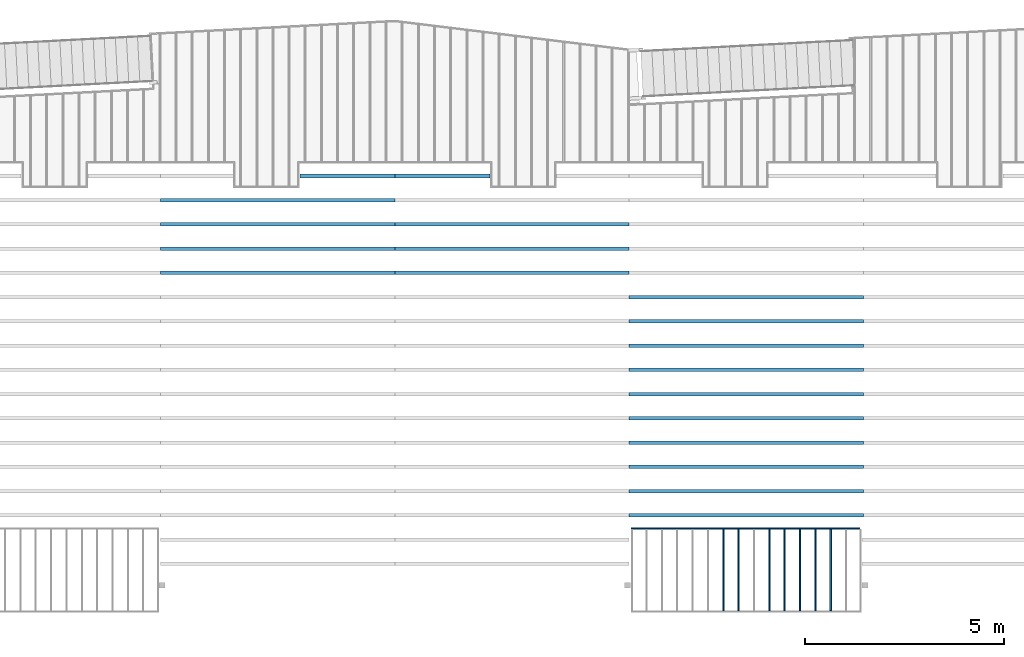
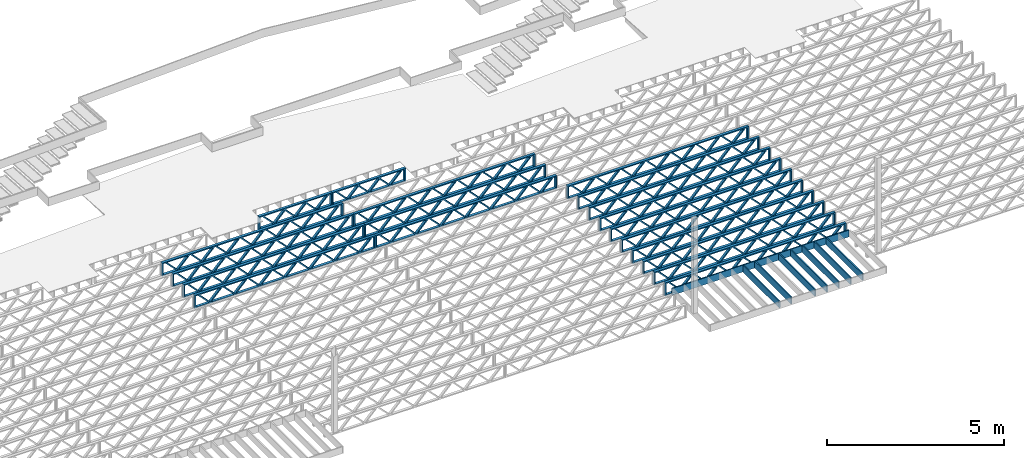
# One storey, part 7 of 23: 27 beams, 4 elements without a shape of their own.
"""IFC4 building model written with IfcOpenShell, lengths in feet."""

import ifcopenshell
import ifcopenshell.guid

model = None  # the IFC model being written
_history = None  # IfcOwnerHistory: only IFC2X3 demands one
_inside = {}  # id of a spatial element -> (the spatial element, [elements in it])
_under = {}  # id of a project, library or spatial element -> (it, [spatial elements below it])
_declared = {}  # id of a project -> (the project, [libraries it declares])
_typed = {}  # id of a type object -> (the type object, [elements of that type])
_made_of = {}  # id of a material, layer set ... -> (it, [elements and type objects made of it])


def new_model(schema):
    """Start an empty IFC model of exactly this schema.

    Asked for "IFC4X3", IfcOpenShell would pick the latest addendum, in which some entities
    have other attributes; the version numbers below select the first issue.
    IFC2X3 requires an IfcOwnerHistory on every rooted entity: one is made here for all.
    """
    global model, _history
    if schema == "IFC4X3":
        model = ifcopenshell.file(schema_version=(4, 3, 0, 0))
    else:
        model = ifcopenshell.file(schema=schema)
    _inside.clear()
    _under.clear()
    _declared.clear()
    _typed.clear()
    _made_of.clear()
    _history = None
    if model.schema == "IFC2X3":
        org = make("IfcOrganization", Name="unknown")
        user = make(
            "IfcPersonAndOrganization",
            ThePerson=make("IfcPerson", FamilyName="unknown"),
            TheOrganization=org,
        )
        app = make(
            "IfcApplication",
            ApplicationDeveloper=org,
            Version="unknown",
            ApplicationFullName="unknown",
            ApplicationIdentifier="unknown",
        )
        _history = make(
            "IfcOwnerHistory",
            OwningUser=user,
            OwningApplication=app,
            ChangeAction="ADDED",
            CreationDate=0,
        )
    return model


def make(cls, **values):
    """One entity of the class cls with the attributes given. An attribute that is None is left unset."""
    return model.create_entity(
        cls, **{name: value for name, value in values.items() if value is not None}
    )


def entity(cls, *values):
    """Any entity or typed value of the class cls, its attributes in the order of the schema. None: left unset."""
    e = model.create_entity(cls)
    for i, value in enumerate(values):
        if value is not None:
            e[i] = value
    return e


def rooted(cls, **values):
    """An entity with a GlobalId (a new one), such as an element, a storey or a relation."""
    return make(cls, GlobalId=ifcopenshell.guid.new(), OwnerHistory=_history, **values)


def si_unit(unit_type, name, prefix=None):
    """IfcSIUnit, for example si_unit("LENGTHUNIT", "METRE", prefix="MILLI")."""
    return make("IfcSIUnit", UnitType=unit_type, Prefix=prefix, Name=name)


def converted_unit(unit_type, name, factor, base, dimensions=None, offset=None):
    """IfcConversionBasedUnit, such as the inch: factor (a typed value) times the base unit."""
    return make(
        "IfcConversionBasedUnit"
        if offset is None
        else "IfcConversionBasedUnitWithOffset",
        ConversionOffset=offset,
        Dimensions=None
        if dimensions is None
        else entity("IfcDimensionalExponents", *dimensions),
        UnitType=unit_type,
        Name=name,
        ConversionFactor=make(
            "IfcMeasureWithUnit", ValueComponent=factor, UnitComponent=base
        ),
    )


def derived_unit(unit_type, elements):
    """IfcDerivedUnit: a product of units, each with its exponent."""
    return make(
        "IfcDerivedUnit",
        Elements=[
            make("IfcDerivedUnitElement", Unit=unit, Exponent=power)
            for unit, power in elements
        ],
        UnitType=unit_type,
    )


def assignment(units):
    """IfcUnitAssignment: the units of a project."""
    return None if units is None else make("IfcUnitAssignment", Units=units)


def point(xyz):
    """IfcCartesianPoint."""
    return None if xyz is None else make("IfcCartesianPoint", Coordinates=xyz)


def direction(xyz):
    """IfcDirection."""
    return None if xyz is None else make("IfcDirection", DirectionRatios=xyz)


def frame(location, z_axis=None, x_axis=None):
    """IfcAxis2Placement3D, a coordinate frame: its origin and axes. An axis left out is left unset."""
    return make(
        "IfcAxis2Placement3D",
        Location=point(location),
        Axis=direction(z_axis),
        RefDirection=direction(x_axis),
    )


def frame_2d(location, x_axis=None):
    """IfcAxis2Placement2D, a coordinate frame in the plane: its origin and x axis."""
    return make(
        "IfcAxis2Placement2D", Location=point(location), RefDirection=direction(x_axis)
    )


def origin():
    """The frame at (0, 0, 0) with its axes left unset."""
    return frame((0.0, 0.0, 0.0))


def origin_2d_with_axis():
    """The frame at (0, 0) in the plane with the x axis (1, 0) written out."""
    return frame_2d((0.0, 0.0), x_axis=(1.0, 0.0))


def place(relative_to, where):
    """IfcLocalPlacement: puts the frame where relative to a parent placement (None: the world)."""
    return make(
        "IfcLocalPlacement", PlacementRelTo=relative_to, RelativePlacement=where
    )


def context(
    kind, dimensions, precision=None, world=None, true_north=None, identifier=None
):
    """IfcGeometricRepresentationContext, for example the 3D "Model" context."""
    return make(
        "IfcGeometricRepresentationContext",
        ContextIdentifier=identifier,
        ContextType=kind,
        CoordinateSpaceDimension=dimensions,
        Precision=precision,
        WorldCoordinateSystem=world,
        TrueNorth=true_north,
    )


def subcontext(parent, identifier, kind, view, scale=None):
    """IfcGeometricRepresentationSubContext, for example "Body" below "Model"."""
    return make(
        "IfcGeometricRepresentationSubContext",
        ContextIdentifier=identifier,
        ContextType=kind,
        ParentContext=parent,
        TargetScale=scale,
        TargetView=view,
    )


def project(units=None, contexts=None):
    """IfcProject with its units and contexts."""
    return rooted(
        "IfcProject",
        Name="project",
        RepresentationContexts=contexts,
        UnitsInContext=assignment(units),
    )


def spatial(cls, under=None, at=None, **own):
    """A site, building, storey or space (cls), placed at a placement, below another one or the project."""
    s = rooted(cls, ObjectPlacement=at, **own)
    if under is not None:
        _under.setdefault(under.id(), (under, []))[1].append(s)
    return s


def profile(cls, at=None, kind="AREA", **sizes):
    """A parametric profile (cls). Its sizes go by their IFC names, for example OverallWidth=200.0."""
    return make(cls, ProfileType=kind, Position=at, **sizes)


def rectangle(**sizes):
    """IfcRectangleProfileDef."""
    return profile("IfcRectangleProfileDef", **sizes)


def extrude(swept, where, along, depth):
    """IfcExtrudedAreaSolid: the profile swept, set in the frame where, extruded along a direction by depth."""
    return make(
        "IfcExtrudedAreaSolid",
        SweptArea=swept,
        Position=where,
        ExtrudedDirection=direction(along),
        Depth=depth,
    )


def shape(context_of_items, identifier, shape_type, items):
    """IfcShapeRepresentation: the items that make up one representation, for example the "Body"."""
    return make(
        "IfcShapeRepresentation",
        ContextOfItems=context_of_items,
        RepresentationIdentifier=identifier,
        RepresentationType=shape_type,
        Items=items,
    )


def source(mapping_origin, context_of_items, identifier, shape_type, items):
    """IfcRepresentationMap: a shape defined once, which mapped items show again and again."""
    return make(
        "IfcRepresentationMap",
        MappingOrigin=mapping_origin,
        MappedRepresentation=shape(context_of_items, identifier, shape_type, items),
    )


def transform(
    local_origin,
    x_axis=None,
    y_axis=None,
    z_axis=None,
    scale=None,
    scale2=None,
    scale3=None,
    uniform=True,
):
    """IfcCartesianTransformationOperator3D, or its non-uniform kind. x_axis, y_axis, z_axis: its Axis1, 2, 3."""
    if uniform:
        return make(
            "IfcCartesianTransformationOperator3D",
            Axis1=direction(x_axis),
            Axis2=direction(y_axis),
            LocalOrigin=point(local_origin),
            Scale=scale,
            Axis3=direction(z_axis),
        )
    return make(
        "IfcCartesianTransformationOperator3DnonUniform",
        Axis1=direction(x_axis),
        Axis2=direction(y_axis),
        LocalOrigin=point(local_origin),
        Scale=scale,
        Axis3=direction(z_axis),
        Scale2=scale2,
        Scale3=scale3,
    )


def mapped(mapping_source, mapping_target):
    """IfcMappedItem: shows the shape of a source again, moved by a transform."""
    return make(
        "IfcMappedItem", MappingSource=mapping_source, MappingTarget=mapping_target
    )


def material(Name=None, Category=None):
    """IfcMaterial."""
    return make("IfcMaterial", Name=Name, Category=Category)


def material_profile(
    of_material, cross_section, Name=None, Category=None, Priority=None
):
    """IfcMaterialProfile: a cross section and its material."""
    return make(
        "IfcMaterialProfile",
        Name=Name,
        Material=of_material,
        Profile=cross_section,
        Priority=Priority,
        Category=Category,
    )


def profile_set(profiles, Name=None, composite=None):
    """IfcMaterialProfileSet."""
    return make(
        "IfcMaterialProfileSet",
        Name=Name,
        MaterialProfiles=profiles,
        CompositeProfile=composite,
    )


def profile_usage(for_profile_set, cardinal=None, extent=None):
    """IfcMaterialProfileSetUsage: how a profile set lies along its element."""
    return make(
        "IfcMaterialProfileSetUsage",
        ForProfileSet=for_profile_set,
        CardinalPoint=cardinal,
        ReferenceExtent=extent,
    )


def made_of(thing, what):
    """Note that an element or type object is made of a material, layer set ...; save() writes the relation."""
    if what is not None:
        _made_of.setdefault(what.id(), (what, []))[1].append(thing)
    return thing


def type_object(cls, material=None, **own):
    """A type object (cls), such as IfcWallType, which elements share."""
    return made_of(rooted(cls, **own), material)


def type_shapes(of_type, sources):
    """Give a type object the sources (RepresentationMaps) that its elements show as mapped items."""
    of_type.RepresentationMaps = sources


def element(
    cls,
    number,
    at=None,
    inside=None,
    cuts=None,
    type_object=None,
    material=None,
    context=None,
    identifier="Body",
    shape_type=None,
    held_by="IfcProductDefinitionShape",
    body=None,
    shapes=None,
    **own,
):
    """One element of the class cls, such as IfcWall. Its Tag is "e" and its number.

    at: its placement. inside: the storey or other place that contains it. cuts: it is an
    opening in that element (IfcRelVoidsElement). A single representation is given by context,
    identifier, shape_type and body (its items); several are given by shapes. held_by: the class
    of the entity that holds the representations. save() writes the other relations.
    """
    e = rooted(cls, Tag="e%d" % number, ObjectPlacement=at, **own)
    if body is not None:
        shapes = [shape(context, identifier, shape_type, body)]
    if shapes is not None:
        e.Representation = make(held_by, Representations=shapes)
    if inside is not None:
        _inside.setdefault(inside.id(), (inside, []))[1].append(e)
    if cuts is not None:
        rooted(
            "IfcRelVoidsElement", RelatingBuildingElement=cuts, RelatedOpeningElement=e
        )
    if type_object is not None:
        _typed.setdefault(type_object.id(), (type_object, []))[1].append(e)
    return made_of(e, material)


def aggregate(whole, parts):
    """IfcRelAggregates: a whole, such as a stair, and the parts it consists of."""
    return rooted("IfcRelAggregates", RelatingObject=whole, RelatedObjects=parts)


def save(model, path):
    """Write the relations noted so far, then the file.

    IfcRelAggregates (storeys below a building ...), IfcRelContainedInSpatialStructure (elements
    in a storey), IfcRelDefinesByType, IfcRelAssociatesMaterial and IfcRelDeclares: one each for
    every whole, place, type object, material and project.
    """
    for whole, parts in _under.values():
        aggregate(whole, parts)
    for where, things in _inside.values():
        rooted(
            "IfcRelContainedInSpatialStructure",
            RelatedElements=things,
            RelatingStructure=where,
        )
    for kind, things in _typed.values():
        rooted("IfcRelDefinesByType", RelatedObjects=things, RelatingType=kind)
    for what, things in _made_of.values():
        rooted("IfcRelAssociatesMaterial", RelatedObjects=things, RelatingMaterial=what)
    for by, libraries in _declared.values():
        rooted("IfcRelDeclares", RelatingContext=by, RelatedDefinitions=libraries)
    model.write(path)


model = new_model("IFC4")

# Units and contexts
model_context = context("Model", 3, precision=0.0001, world=origin(), true_north=direction((6.12303176911189e-17, 1.0)))
body_context = subcontext(model_context, "Body", "Model", "MODEL_VIEW")
ifc_project = project(units=[converted_unit("LENGTHUNIT", "FOOT", entity("IfcRatioMeasure", 0.3048), si_unit("LENGTHUNIT", "METRE"), dimensions=[1, 0, 0, 0, 0, 0, 0]), converted_unit("AREAUNIT", "SQUARE FOOT", entity("IfcRatioMeasure", 0.09290304), si_unit("AREAUNIT", "SQUARE_METRE"), dimensions=[2, 0, 0, 0, 0, 0, 0]), converted_unit("VOLUMEUNIT", "CUBIC FOOT", entity("IfcRatioMeasure", 0.028316846592), si_unit("VOLUMEUNIT", "CUBIC_METRE"), dimensions=[3, 0, 0, 0, 0, 0, 0]), converted_unit("PLANEANGLEUNIT", "DEGREE", entity("IfcRatioMeasure", 0.0174532925199433), si_unit("PLANEANGLEUNIT", "RADIAN"), dimensions=[0, 0, 0, 0, 0, 0, 0]), si_unit("MASSUNIT", "GRAM", prefix="KILO"), derived_unit("MASSDENSITYUNIT", [(si_unit("MASSUNIT", "GRAM", prefix="KILO"), 1), (si_unit("LENGTHUNIT", "METRE"), -3)]), derived_unit("MOMENTOFINERTIAUNIT", [(si_unit("LENGTHUNIT", "METRE"), 4)]), si_unit("TIMEUNIT", "SECOND"), si_unit("FREQUENCYUNIT", "HERTZ"), si_unit("THERMODYNAMICTEMPERATUREUNIT", "DEGREE_CELSIUS"), derived_unit("THERMALTRANSMITTANCEUNIT", [(si_unit("MASSUNIT", "GRAM", prefix="KILO"), 1), (si_unit("THERMODYNAMICTEMPERATUREUNIT", "KELVIN"), -1), (si_unit("TIMEUNIT", "SECOND"), -3)]), derived_unit("VOLUMETRICFLOWRATEUNIT", [(si_unit("LENGTHUNIT", "METRE"), 3), (si_unit("TIMEUNIT", "SECOND"), -1)]), si_unit("ELECTRICCURRENTUNIT", "AMPERE"), si_unit("ELECTRICVOLTAGEUNIT", "VOLT"), si_unit("POWERUNIT", "WATT"), si_unit("FORCEUNIT", "NEWTON"), si_unit("ILLUMINANCEUNIT", "LUX"), si_unit("LUMINOUSFLUXUNIT", "LUMEN"), si_unit("LUMINOUSINTENSITYUNIT", "CANDELA"), derived_unit("USERDEFINED", [(si_unit("MASSUNIT", "GRAM", prefix="KILO"), -1), (si_unit("LENGTHUNIT", "METRE"), -2), (si_unit("TIMEUNIT", "SECOND"), 3), (si_unit("LUMINOUSFLUXUNIT", "LUMEN"), 1)]), derived_unit("LINEARVELOCITYUNIT", [(si_unit("LENGTHUNIT", "METRE"), 1), (si_unit("TIMEUNIT", "SECOND"), -1)]), si_unit("PRESSUREUNIT", "PASCAL"), derived_unit("USERDEFINED", [(si_unit("LENGTHUNIT", "METRE"), -2), (si_unit("MASSUNIT", "GRAM", prefix="KILO"), 1), (si_unit("TIMEUNIT", "SECOND"), -2)]), derived_unit("LINEARFORCEUNIT", [(si_unit("MASSUNIT", "GRAM", prefix="KILO"), 1), (si_unit("LENGTHUNIT", "METRE"), 1), (si_unit("TIMEUNIT", "SECOND"), -2), (si_unit("LENGTHUNIT", "METRE"), -1)]), derived_unit("PLANARFORCEUNIT", [(si_unit("MASSUNIT", "GRAM", prefix="KILO"), 1), (si_unit("LENGTHUNIT", "METRE"), 1), (si_unit("TIMEUNIT", "SECOND"), -2), (si_unit("LENGTHUNIT", "METRE"), -2)])], contexts=[model_context])

# Site, building, storey
site_placement = place(None, origin())
site = spatial("IfcSite", under=ifc_project, at=site_placement, CompositionType="ELEMENT")
building_placement = place(site_placement, origin())
building = spatial("IfcBuilding", under=site, at=building_placement, CompositionType="ELEMENT")
storey_placement = place(building_placement, frame((0.0, 0.0, 10.8020833333333)))
storey = spatial("IfcBuildingStorey", under=building, at=storey_placement, Name="2ND FLOOR", CompositionType="ELEMENT", Elevation=10.8020833333333)

# Assembly, beams
assembly_1_placement = place(storey_placement, origin())
assembly_1 = element("IfcElementAssembly", 1, at=assembly_1_placement, inside=storey, Name="Structural Beam System:Structural Framing System", ObjectType="Structural Beam System:Structural Framing System", AssemblyPlace="NOTDEFINED", PredefinedType="BEAM_GRID")
ifc_material_1 = material(Category="Materials")
ifc_material_profile_1 = material_profile(ifc_material_1, rectangle(XDim=0.770833333333333, YDim=0.124999999999994, at=frame_2d((-5.55111512312578e-17, 0.0), x_axis=(1.0, 0.0))))
ifc_profile_set_1 = profile_set([ifc_material_profile_1])
ifc_profile_usage_1 = profile_usage(ifc_profile_set_1, cardinal=8)
beam_type_1 = type_object("IfcBeamType", PredefinedType="BEAM", material=ifc_profile_set_1)
shared_shape_1 = source(origin(), body_context, "Body", "SweptSolid", [
    extrude(rectangle(XDim=0.770833333333333, YDim=0.124999999999994, at=frame_2d((-5.55111512312578e-17, 0.0), x_axis=(1.0, 0.0))), frame((-3.35416666666737, 0.0, 0.0), z_axis=(1.0, 0.0, 0.0), x_axis=(0.0, 0.0, -1.0)), (0.0, 0.0, 1.0), 6.70833333333462),
])
type_shapes(beam_type_1, [shared_shape_1])
beam_1_placement = place(assembly_1_placement, frame((-167.102006703188, 925.341101549316, -0.645833333333471), z_axis=(0.0, 0.0, 1.0), x_axis=(0.0, 1.0, 0.0)))
beam_1 = element("IfcBeam", 2, at=beam_1_placement, type_object=beam_type_1, material=ifc_profile_usage_1, PredefinedType="BEAM", context=body_context, shape_type="MappedRepresentation", body=[
    mapped(shared_shape_1, transform((0.0, 0.0, 0.0), scale=1.0)),
])
ifc_profile_usage_2 = profile_usage(ifc_profile_set_1, cardinal=8)
beam_2_placement = place(assembly_1_placement, frame((-168.368890383746, 925.341101549316, -0.645833333333471), z_axis=(0.0, 0.0, 1.0), x_axis=(0.0, 1.0, 0.0)))
beam_2 = element("IfcBeam", 3, at=beam_2_placement, type_object=beam_type_1, material=ifc_profile_usage_2, PredefinedType="BEAM", context=body_context, shape_type="MappedRepresentation", body=[
    mapped(shared_shape_1, transform((0.0, 0.0, 0.0), scale=1.0)),
])
ifc_profile_usage_3 = profile_usage(ifc_profile_set_1, cardinal=8)
beam_3_placement = place(assembly_1_placement, frame((-169.635774064305, 925.341101549317, -0.645833333333471), z_axis=(0.0, 0.0, 1.0), x_axis=(0.0, 1.0, 0.0)))
beam_3 = element("IfcBeam", 4, at=beam_3_placement, type_object=beam_type_1, material=ifc_profile_usage_3, PredefinedType="BEAM", context=body_context, shape_type="MappedRepresentation", body=[
    mapped(shared_shape_1, transform((0.0, 0.0, 0.0), scale=1.0)),
])
ifc_profile_usage_4 = profile_usage(ifc_profile_set_1, cardinal=8)
beam_4_placement = place(assembly_1_placement, frame((-170.902657744863, 925.341101549317, -0.645833333333471), z_axis=(0.0, 0.0, 1.0), x_axis=(0.0, 1.0, 0.0)))
beam_4 = element("IfcBeam", 5, at=beam_4_placement, type_object=beam_type_1, material=ifc_profile_usage_4, PredefinedType="BEAM", context=body_context, shape_type="MappedRepresentation", body=[
    mapped(shared_shape_1, transform((0.0, 0.0, 0.0), scale=1.0)),
])
ifc_profile_usage_5 = profile_usage(ifc_profile_set_1, cardinal=8)
beam_5_placement = place(assembly_1_placement, frame((-172.169541425421, 925.341101549317, -0.645833333333471), z_axis=(0.0, 0.0, 1.0), x_axis=(0.0, 1.0, 0.0)))
beam_5 = element("IfcBeam", 6, at=beam_5_placement, type_object=beam_type_1, material=ifc_profile_usage_5, PredefinedType="BEAM", context=body_context, shape_type="MappedRepresentation", body=[
    mapped(shared_shape_1, transform((0.0, 0.0, 0.0), scale=1.0)),
])
ifc_profile_usage_6 = profile_usage(ifc_profile_set_1, cardinal=8)
beam_6_placement = place(assembly_1_placement, frame((-174.703308786538, 925.341101549318, -0.645833333333433), z_axis=(0.0, 0.0, 1.0), x_axis=(0.0, 1.0, 0.0)))
beam_6 = element("IfcBeam", 7, at=beam_6_placement, type_object=beam_type_1, material=ifc_profile_usage_6, PredefinedType="BEAM", context=body_context, shape_type="MappedRepresentation", body=[
    mapped(shared_shape_1, transform((0.0, 0.0, 0.0), scale=1.0)),
])
ifc_profile_usage_7 = profile_usage(ifc_profile_set_1, cardinal=8)
beam_7_placement = place(assembly_1_placement, frame((-175.970192467096, 925.341101549318, -0.645833333333471), z_axis=(0.0, 0.0, 1.0), x_axis=(0.0, 1.0, 0.0)))
beam_7 = element("IfcBeam", 8, at=beam_7_placement, type_object=beam_type_1, material=ifc_profile_usage_7, PredefinedType="BEAM", context=body_context, shape_type="MappedRepresentation", body=[
    mapped(shared_shape_1, transform((0.0, 0.0, 0.0), scale=1.0)),
])
aggregate(assembly_1, [beam_1, beam_2, beam_3, beam_4, beam_5, beam_6, beam_7])

assembly_2_placement = place(storey_placement, origin())
assembly_2 = element("IfcElementAssembly", 9, at=assembly_2_placement, inside=storey, Name="Structural Beam System:Structural Framing System", ObjectType="Structural Beam System:Structural Framing System", AssemblyPlace="NOTDEFINED", PredefinedType="BEAM_GRID")
ifc_material_2 = material(Name="WOOD TRUSS", Category="Materials")
ifc_material_profile_2 = material_profile(ifc_material_2, rectangle(XDim=1.73473973950632, YDim=0.125, at=frame_2d((-1.11022302462516e-16, 8.32667268468867e-17), x_axis=(1.0, 0.0))))
ifc_material_profile_3 = material_profile(ifc_material_2, rectangle(XDim=1.73473973950633, YDim=0.125, at=frame_2d((-1.11022302462516e-16, 8.32667268468867e-17), x_axis=(1.0, 0.0))))
ifc_material_profile_4 = material_profile(ifc_material_2, rectangle(XDim=1.73473973950632, YDim=0.125, at=frame_2d((-5.55111512312578e-17, 1.38777878078145e-16), x_axis=(1.0, 0.0))))
ifc_material_profile_5 = material_profile(ifc_material_2, rectangle(XDim=1.73473973950633, YDim=0.125, at=frame_2d((-1.11022302462516e-16, 8.32667268468867e-17), x_axis=(1.0, 0.0))))
ifc_material_profile_6 = material_profile(ifc_material_2, rectangle(XDim=1.73473973950632, YDim=0.125, at=frame_2d((-1.11022302462516e-16, 8.32667268468867e-17), x_axis=(1.0, 0.0))))
ifc_material_profile_7 = material_profile(ifc_material_2, rectangle(XDim=1.73473973950633, YDim=0.125, at=frame_2d((-2.77555756156289e-16, 3.05311331771918e-16), x_axis=(1.0, 0.0))))
ifc_material_profile_8 = material_profile(ifc_material_2, rectangle(XDim=1.73473973950632, YDim=0.124999999999999, at=frame_2d((-3.88578058618805e-16, -2.4980018054066e-16), x_axis=(1.0, 0.0))))
ifc_material_profile_9 = material_profile(ifc_material_2, rectangle(XDim=1.73473973950633, YDim=0.125, at=frame_2d((2.77555756156289e-16, -3.05311331771918e-16), x_axis=(1.0, 0.0))))
ifc_material_profile_10 = material_profile(ifc_material_2, rectangle(XDim=1.73473973950632, YDim=0.124999999999999, at=frame_2d((-1.11022302462516e-16, 8.32667268468867e-17), x_axis=(1.0, 0.0))))
ifc_material_profile_11 = material_profile(ifc_material_2, rectangle(XDim=1.73473973950633, YDim=0.125, at=origin_2d_with_axis()))
ifc_material_profile_12 = material_profile(ifc_material_2, rectangle(XDim=0.124999999999982, YDim=0.291666666666668, at=origin_2d_with_axis()))
ifc_material_profile_13 = material_profile(ifc_material_2, rectangle(XDim=0.124999999999932, YDim=0.291666666666664, at=origin_2d_with_axis()))
ifc_material_profile_14 = material_profile(ifc_material_2, rectangle(XDim=1.25000000000002, YDim=0.29166666666667, at=origin_2d_with_axis()))
ifc_material_profile_15 = material_profile(ifc_material_2, rectangle(XDim=1.25000000000004, YDim=0.291666666666667, at=origin_2d_with_axis()))
ifc_profile_set_2 = profile_set([ifc_material_profile_2, ifc_material_profile_3, ifc_material_profile_4, ifc_material_profile_5, ifc_material_profile_6, ifc_material_profile_7, ifc_material_profile_8, ifc_material_profile_9, ifc_material_profile_10, ifc_material_profile_11, ifc_material_profile_12, ifc_material_profile_13, ifc_material_profile_14, ifc_material_profile_15])
ifc_profile_usage_8 = profile_usage(ifc_profile_set_2, cardinal=8)
beam_type_2 = type_object("IfcBeamType", PredefinedType="BEAM", material=ifc_profile_set_2)
shared_shape_2 = source(origin(), body_context, "Body", "SweptSolid", [
    extrude(rectangle(XDim=1.73473973950632, YDim=0.124999999999999, at=frame_2d((5.55111512312578e-16, 7.21644966006352e-16), x_axis=(1.0, 0.0))), frame((5.95847627016997, -0.145833333333334, 0.0), z_axis=(0.0, 1.0, 0.0), x_axis=(0.693383046997606, 0.0, 0.720569184836762)), (0.0, 0.0, 1.0), 0.291666666666667),
    extrude(rectangle(XDim=1.73473973950633, YDim=0.125, at=origin_2d_with_axis()), frame((4.7081903964967, -0.145833333333334, 0.0), z_axis=(0.0, 1.0, 0.0), x_axis=(0.69338304699761, 0.0, -0.720569184836758)), (0.0, 0.0, 1.0), 0.291666666666666),
    extrude(rectangle(XDim=1.73473973950632, YDim=0.125, at=frame_2d((2.22044604925031e-16, 3.88578058618805e-16), x_axis=(1.0, 0.0))), frame((3.29180960350347, -0.145833333333334, 0.0), z_axis=(0.0, 1.0, 0.0), x_axis=(0.693383046997606, 0.0, 0.720569184836762)), (0.0, 0.0, 1.0), 0.291666666666667),
    extrude(rectangle(XDim=1.73473973950633, YDim=0.125, at=frame_2d((1.11022302462516e-16, -8.32667268468867e-17), x_axis=(1.0, 0.0))), frame((2.0415237298302, -0.145833333333334, 0.0), z_axis=(0.0, 1.0, 0.0), x_axis=(0.69338304699761, 0.0, -0.720569184836758)), (0.0, 0.0, 1.0), 0.291666666666667),
    extrude(rectangle(XDim=1.73473973950632, YDim=0.125, at=frame_2d((-5.55111512312578e-17, 1.38777878078145e-16), x_axis=(1.0, 0.0))), frame((0.625142936836964, -0.145833333333334, 0.0), z_axis=(0.0, 1.0, 0.0), x_axis=(0.693383046997606, 0.0, 0.720569184836762)), (0.0, 0.0, 1.0), 0.291666666666667),
    extrude(rectangle(XDim=1.73473973950633, YDim=0.125, at=frame_2d((-1.11022302462516e-16, 8.32667268468867e-17), x_axis=(1.0, 0.0))), frame((-0.625142936836306, -0.145833333333334, 0.0), z_axis=(0.0, 1.0, 0.0), x_axis=(0.69338304699761, 0.0, -0.720569184836758)), (0.0, 0.0, 1.0), 0.291666666666667),
    extrude(rectangle(XDim=1.73473973950632, YDim=0.125, at=frame_2d((-1.11022302462516e-16, 8.32667268468867e-17), x_axis=(1.0, 0.0))), frame((-2.04152372982954, -0.145833333333334, 0.0), z_axis=(0.0, 1.0, 0.0), x_axis=(0.693383046997606, 0.0, 0.720569184836762)), (0.0, 0.0, 1.0), 0.291666666666667),
    extrude(rectangle(XDim=1.73473973950633, YDim=0.125, at=origin_2d_with_axis()), frame((-3.29180960350281, -0.145833333333334, 0.0), z_axis=(0.0, 1.0, 0.0), x_axis=(0.69338304699761, 0.0, -0.720569184836758)), (0.0, 0.0, 1.0), 0.291666666666667),
    extrude(rectangle(XDim=1.73473973950632, YDim=0.124999999999999, at=frame_2d((-1.11022302462516e-16, 8.32667268468867e-17), x_axis=(1.0, 0.0))), frame((-4.70819039649604, -0.145833333333334, 0.0), z_axis=(0.0, 1.0, 0.0), x_axis=(0.693383046997606, 0.0, 0.720569184836762)), (0.0, 0.0, 1.0), 0.291666666666667),
    extrude(rectangle(XDim=1.73473973950633, YDim=0.125, at=frame_2d((-5.55111512312578e-16, 6.38378239159465e-16), x_axis=(1.0, 0.0))), frame((-5.95847627016931, -0.145833333333334, 0.0), z_axis=(0.0, 1.0, 0.0), x_axis=(0.69338304699761, 0.0, -0.720569184836758)), (0.0, 0.0, 1.0), 0.291666666666666),
    extrude(rectangle(XDim=1.73473973950632, YDim=0.125, at=frame_2d((-7.21644966006352e-16, -5.82867087928207e-16), x_axis=(1.0, 0.0))), frame((8.62514293683647, -0.145833333333334, 0.0), z_axis=(0.0, 1.0, 0.0), x_axis=(0.693383046997607, 0.0, 0.720569184836761)), (0.0, 0.0, 1.0), 0.291666666666667),
    extrude(rectangle(XDim=1.73473973950633, YDim=0.125, at=origin_2d_with_axis()), frame((7.3748570631632, -0.145833333333334, 0.0), z_axis=(0.0, 1.0, 0.0), x_axis=(0.69338304699761, 0.0, -0.720569184836758)), (0.0, 0.0, 1.0), 0.291666666666666),
    extrude(rectangle(XDim=1.73473973950632, YDim=0.124999999999999, at=frame_2d((-1.11022302462516e-16, 8.32667268468867e-17), x_axis=(1.0, 0.0))), frame((-7.37485706316255, -0.145833333333334, 0.0), z_axis=(0.0, 1.0, 0.0), x_axis=(0.693383046997606, 0.0, 0.720569184836762)), (0.0, 0.0, 1.0), 0.291666666666667),
    extrude(rectangle(XDim=1.73473973950633, YDim=0.125, at=origin_2d_with_axis()), frame((-8.62514293683582, -0.145833333333334, 0.0), z_axis=(0.0, 1.0, 0.0), x_axis=(0.69338304699761, 0.0, -0.720569184836758)), (0.0, 0.0, 1.0), 0.291666666666666),
    extrude(rectangle(XDim=0.124999999999982, YDim=0.291666666666668, at=origin_2d_with_axis()), frame((-9.66666666666609, 0.0, 0.687500000000054), z_axis=(1.0, 0.0, 0.0), x_axis=(0.0, 0.0, -1.0)), (0.0, 0.0, 1.0), 19.3333333333322),
    extrude(rectangle(XDim=0.124999999999932, YDim=0.291666666666664, at=origin_2d_with_axis()), frame((-9.66666666666588, 0.0, -0.687499999999984), z_axis=(1.0, 0.0, 0.0), x_axis=(0.0, 0.0, -1.0)), (0.0, 0.0, 1.0), 19.333333333332),
    extrude(rectangle(XDim=1.25000000000002, YDim=0.29166666666667, at=origin_2d_with_axis()), frame((9.54166666666607, 0.0, 0.0), z_axis=(1.0, 0.0, 0.0), x_axis=(0.0, 0.0, -1.0)), (0.0, 0.0, 1.0), 0.12500000000002),
    extrude(rectangle(XDim=1.25000000000004, YDim=0.291666666666667, at=origin_2d_with_axis()), frame((-9.66666666666609, 0.0, 0.0), z_axis=(1.0, 0.0, 0.0), x_axis=(0.0, 0.0, -1.0)), (0.0, 0.0, 1.0), 0.125000000000023),
])
type_shapes(beam_type_2, [shared_shape_2])
beam_8_placement = place(assembly_2_placement, frame((-174.071493818896, 947.861934882651, -0.947916666666657), z_axis=(0.0, 0.0, 1.0), x_axis=(-1.0, 0.0, 0.0)))
beam_8 = element("IfcBeam", 10, at=beam_8_placement, type_object=beam_type_2, material=ifc_profile_usage_8, PredefinedType="BEAM", context=body_context, shape_type="MappedRepresentation", body=[
    mapped(shared_shape_2, transform((0.0, 0.0, 0.0), scale=1.0)),
])
ifc_profile_usage_9 = profile_usage(ifc_profile_set_2, cardinal=8)
beam_9_placement = place(assembly_2_placement, frame((-174.071493818896, 945.861934882651, -0.947916666666657), z_axis=(0.0, 0.0, 1.0), x_axis=(-1.0, 0.0, 0.0)))
beam_9 = element("IfcBeam", 11, at=beam_9_placement, type_object=beam_type_2, material=ifc_profile_usage_9, PredefinedType="BEAM", context=body_context, shape_type="MappedRepresentation", body=[
    mapped(shared_shape_2, transform((0.0, 0.0, 0.0), scale=1.0)),
])
ifc_profile_usage_10 = profile_usage(ifc_profile_set_2, cardinal=8)
beam_10_placement = place(assembly_2_placement, frame((-174.071493818896, 943.861934882651, -0.947916666666657), z_axis=(0.0, 0.0, 1.0), x_axis=(-1.0, 0.0, 0.0)))
beam_10 = element("IfcBeam", 12, at=beam_10_placement, type_object=beam_type_2, material=ifc_profile_usage_10, PredefinedType="BEAM", context=body_context, shape_type="MappedRepresentation", body=[
    mapped(shared_shape_2, transform((0.0, 0.0, 0.0), scale=1.0)),
])
ifc_profile_usage_11 = profile_usage(ifc_profile_set_2, cardinal=8)
beam_11_placement = place(assembly_2_placement, frame((-174.071493818896, 941.861934882651, -0.947916666666657), z_axis=(0.0, 0.0, 1.0), x_axis=(-1.0, 0.0, 0.0)))
beam_11 = element("IfcBeam", 13, at=beam_11_placement, type_object=beam_type_2, material=ifc_profile_usage_11, PredefinedType="BEAM", context=body_context, shape_type="MappedRepresentation", body=[
    mapped(shared_shape_2, transform((0.0, 0.0, 0.0), scale=1.0)),
])
ifc_profile_usage_12 = profile_usage(ifc_profile_set_2, cardinal=8)
beam_12_placement = place(assembly_2_placement, frame((-174.071493818896, 939.861934882651, -0.947916666666657), z_axis=(0.0, 0.0, 1.0), x_axis=(-1.0, 0.0, 0.0)))
beam_12 = element("IfcBeam", 14, at=beam_12_placement, type_object=beam_type_2, material=ifc_profile_usage_12, PredefinedType="BEAM", context=body_context, shape_type="MappedRepresentation", body=[
    mapped(shared_shape_2, transform((0.0, 0.0, 0.0), scale=1.0)),
])
ifc_profile_usage_13 = profile_usage(ifc_profile_set_2, cardinal=8)
beam_13_placement = place(assembly_2_placement, frame((-174.071493818896, 937.861934882651, -0.947916666666657), z_axis=(0.0, 0.0, 1.0), x_axis=(-1.0, 0.0, 0.0)))
beam_13 = element("IfcBeam", 15, at=beam_13_placement, type_object=beam_type_2, material=ifc_profile_usage_13, PredefinedType="BEAM", context=body_context, shape_type="MappedRepresentation", body=[
    mapped(shared_shape_2, transform((0.0, 0.0, 0.0), scale=1.0)),
])
ifc_profile_usage_14 = profile_usage(ifc_profile_set_2, cardinal=8)
beam_14_placement = place(assembly_2_placement, frame((-174.071493818896, 935.861934882651, -0.947916666666657), z_axis=(0.0, 0.0, 1.0), x_axis=(-1.0, 0.0, 0.0)))
beam_14 = element("IfcBeam", 16, at=beam_14_placement, type_object=beam_type_2, material=ifc_profile_usage_14, PredefinedType="BEAM", context=body_context, shape_type="MappedRepresentation", body=[
    mapped(shared_shape_2, transform((0.0, 0.0, 0.0), scale=1.0)),
])
ifc_profile_usage_15 = profile_usage(ifc_profile_set_2, cardinal=8)
beam_15_placement = place(assembly_2_placement, frame((-174.071493818896, 933.861934882651, -0.947916666666657), z_axis=(0.0, 0.0, 1.0), x_axis=(-1.0, 0.0, 0.0)))
beam_15 = element("IfcBeam", 17, at=beam_15_placement, type_object=beam_type_2, material=ifc_profile_usage_15, PredefinedType="BEAM", context=body_context, shape_type="MappedRepresentation", body=[
    mapped(shared_shape_2, transform((0.0, 0.0, 0.0), scale=1.0)),
])
ifc_profile_usage_16 = profile_usage(ifc_profile_set_2, cardinal=8)
beam_16_placement = place(assembly_2_placement, frame((-174.071493818896, 931.861934882651, -0.947916666666657), z_axis=(0.0, 0.0, 1.0), x_axis=(-1.0, 0.0, 0.0)))
beam_16 = element("IfcBeam", 18, at=beam_16_placement, type_object=beam_type_2, material=ifc_profile_usage_16, PredefinedType="BEAM", context=body_context, shape_type="MappedRepresentation", body=[
    mapped(shared_shape_2, transform((0.0, 0.0, 0.0), scale=1.0)),
])
ifc_profile_usage_17 = profile_usage(ifc_profile_set_2, cardinal=8)
beam_17_placement = place(assembly_2_placement, frame((-174.071493818896, 929.861934882651, -0.947916666666657), z_axis=(0.0, 0.0, 1.0), x_axis=(-1.0, 0.0, 0.0)))
beam_17 = element("IfcBeam", 19, at=beam_17_placement, type_object=beam_type_2, material=ifc_profile_usage_17, PredefinedType="BEAM", context=body_context, shape_type="MappedRepresentation", body=[
    mapped(shared_shape_2, transform((0.0, 0.0, 0.0), scale=1.0)),
])
aggregate(assembly_2, [beam_8, beam_9, beam_10, beam_11, beam_12, beam_13, beam_14, beam_15, beam_16, beam_17])

assembly_3_placement = place(storey_placement, origin())
assembly_3 = element("IfcElementAssembly", 20, at=assembly_3_placement, inside=storey, Name="Structural Beam System:Structural Framing System", ObjectType="Structural Beam System:Structural Framing System", AssemblyPlace="NOTDEFINED", PredefinedType="BEAM_GRID")
ifc_profile_usage_18 = profile_usage(ifc_profile_set_2, cardinal=8)
beam_18_placement = place(assembly_3_placement, frame((-193.404827152229, 953.861934882651, -0.947916666666881)))
beam_18 = element("IfcBeam", 21, at=beam_18_placement, type_object=beam_type_2, material=ifc_profile_usage_18, PredefinedType="BEAM", context=body_context, shape_type="MappedRepresentation", body=[
    mapped(shared_shape_2, transform((0.0, 0.0, 0.0), scale=1.0)),
])
ifc_profile_usage_19 = profile_usage(ifc_profile_set_2, cardinal=8)
beam_19_placement = place(assembly_3_placement, frame((-193.404827152229, 951.861934882651, -0.947916666666881)))
beam_19 = element("IfcBeam", 22, at=beam_19_placement, type_object=beam_type_2, material=ifc_profile_usage_19, PredefinedType="BEAM", context=body_context, shape_type="MappedRepresentation", body=[
    mapped(shared_shape_2, transform((0.0, 0.0, 0.0), scale=1.0)),
])
ifc_profile_usage_20 = profile_usage(ifc_profile_set_2, cardinal=8)
beam_20_placement = place(assembly_3_placement, frame((-193.404827152229, 949.861934882651, -0.947916666666881)))
beam_20 = element("IfcBeam", 23, at=beam_20_placement, type_object=beam_type_2, material=ifc_profile_usage_20, PredefinedType="BEAM", context=body_context, shape_type="MappedRepresentation", body=[
    mapped(shared_shape_2, transform((0.0, 0.0, 0.0), scale=1.0)),
])

assembly_4_placement = place(storey_placement, origin())
assembly_4 = element("IfcElementAssembly", 24, at=assembly_4_placement, inside=storey, Name="Structural Beam System:Structural Framing System", ObjectType="Structural Beam System:Structural Framing System", AssemblyPlace="NOTDEFINED", PredefinedType="BEAM_GRID")
ifc_profile_usage_21 = profile_usage(ifc_profile_set_2, cardinal=8)
beam_21_placement = place(assembly_4_placement, frame((-212.738160485495, 955.861934882651, -0.947916666666881), z_axis=(0.0, 0.0, 1.0), x_axis=(-1.0, 0.0, 0.0)))
beam_21 = element("IfcBeam", 25, at=beam_21_placement, type_object=beam_type_2, material=ifc_profile_usage_21, PredefinedType="BEAM", context=body_context, shape_type="MappedRepresentation", body=[
    mapped(shared_shape_2, transform((0.0, 0.0, 0.0), scale=1.0)),
])
ifc_profile_usage_22 = profile_usage(ifc_profile_set_2, cardinal=8)
beam_22_placement = place(assembly_4_placement, frame((-212.738160485495, 953.861934882651, -0.947916666666881), z_axis=(0.0, 0.0, 1.0), x_axis=(-1.0, 0.0, 0.0)))
beam_22 = element("IfcBeam", 26, at=beam_22_placement, type_object=beam_type_2, material=ifc_profile_usage_22, PredefinedType="BEAM", context=body_context, shape_type="MappedRepresentation", body=[
    mapped(shared_shape_2, transform((0.0, 0.0, 0.0), scale=1.0)),
])
ifc_profile_usage_23 = profile_usage(ifc_profile_set_2, cardinal=8)
beam_23_placement = place(assembly_4_placement, frame((-212.738160485495, 951.861934882651, -0.947916666666881), z_axis=(0.0, 0.0, 1.0), x_axis=(-1.0, 0.0, 0.0)))
beam_23 = element("IfcBeam", 27, at=beam_23_placement, type_object=beam_type_2, material=ifc_profile_usage_23, PredefinedType="BEAM", context=body_context, shape_type="MappedRepresentation", body=[
    mapped(shared_shape_2, transform((0.0, 0.0, 0.0), scale=1.0)),
])
ifc_profile_usage_24 = profile_usage(ifc_profile_set_2, cardinal=8)
beam_24_placement = place(assembly_4_placement, frame((-212.738160485495, 949.861934882651, -0.947916666666881), z_axis=(0.0, 0.0, 1.0), x_axis=(-1.0, 0.0, 0.0)))
beam_24 = element("IfcBeam", 28, at=beam_24_placement, type_object=beam_type_2, material=ifc_profile_usage_24, PredefinedType="BEAM", context=body_context, shape_type="MappedRepresentation", body=[
    mapped(shared_shape_2, transform((0.0, 0.0, 0.0), scale=1.0)),
])

# Beam
ifc_profile_usage_25 = profile_usage(ifc_profile_set_2, cardinal=8)
beam_type_3 = type_object("IfcBeamType", PredefinedType="BEAM", material=ifc_profile_set_2)
shared_shape_3 = source(origin(), body_context, "Body", "SweptSolid", [
    extrude(rectangle(XDim=1.73473973950632, YDim=0.125, at=frame_2d((-5.55111512312578e-17, 1.38777878078145e-16), x_axis=(1.0, 0.0))), frame((0.625142936836963, -0.145833333333334, 0.0), z_axis=(0.0, 1.0, 0.0), x_axis=(0.693383046997606, 0.0, 0.720569184836762)), (0.0, 0.0, 1.0), 0.291666666666667),
    extrude(rectangle(XDim=1.73473973950633, YDim=0.125, at=frame_2d((-1.11022302462516e-16, 8.32667268468867e-17), x_axis=(1.0, 0.0))), frame((-0.625142936836308, -0.145833333333334, 0.0), z_axis=(0.0, 1.0, 0.0), x_axis=(0.69338304699761, 0.0, -0.720569184836758)), (0.0, 0.0, 1.0), 0.291666666666667),
    extrude(rectangle(XDim=1.73473973950632, YDim=0.125, at=frame_2d((-1.11022302462516e-16, 8.32667268468867e-17), x_axis=(1.0, 0.0))), frame((2.87514285312432, -0.145833333333334, 0.0), z_axis=(0.0, 1.0, 0.0), x_axis=(0.693383046997606, 0.0, 0.720569184836762)), (0.0, 0.0, 1.0), 0.291666666666667),
    extrude(rectangle(XDim=1.73473973950633, YDim=0.125, at=frame_2d((-1.11022302462516e-16, 8.32667268468867e-17), x_axis=(1.0, 0.0))), frame((1.62485697945105, -0.145833333333334, 0.0), z_axis=(0.0, 1.0, 0.0), x_axis=(0.69338304699761, 0.0, -0.720569184836758)), (0.0, 0.0, 1.0), 0.291666666666667),
    extrude(rectangle(XDim=1.73473973950632, YDim=0.125, at=frame_2d((-1.11022302462516e-16, 8.32667268468867e-17), x_axis=(1.0, 0.0))), frame((-1.62485697945039, -0.145833333333334, 0.0), z_axis=(0.0, 1.0, 0.0), x_axis=(0.693383046997606, 0.0, 0.720569184836762)), (0.0, 0.0, 1.0), 0.291666666666667),
    extrude(rectangle(XDim=1.73473973950633, YDim=0.125, at=origin_2d_with_axis()), frame((-2.87514285312366, -0.145833333333334, 0.0), z_axis=(0.0, 1.0, 0.0), x_axis=(0.69338304699761, 0.0, -0.720569184836758)), (0.0, 0.0, 1.0), 0.291666666666667),
    extrude(rectangle(XDim=0.124999999999982, YDim=0.291666666666668, at=origin_2d_with_axis()), frame((-3.91666658295394, 0.0, 0.687500000000054), z_axis=(1.0, 0.0, 0.0), x_axis=(0.0, 0.0, -1.0)), (0.0, 0.0, 1.0), 7.83333316590787),
    extrude(rectangle(XDim=0.124999999999932, YDim=0.291666666666664, at=origin_2d_with_axis()), frame((-3.91666658295372, 0.0, -0.687499999999984), z_axis=(1.0, 0.0, 0.0), x_axis=(0.0, 0.0, -1.0)), (0.0, 0.0, 1.0), 7.83333316590766),
    extrude(rectangle(XDim=1.25000000000002, YDim=0.29166666666667, at=origin_2d_with_axis()), frame((3.79166658295392, 0.0, 0.0), z_axis=(1.0, 0.0, 0.0), x_axis=(0.0, 0.0, -1.0)), (0.0, 0.0, 1.0), 0.12500000000002),
    extrude(rectangle(XDim=1.25000000000004, YDim=0.291666666666667, at=origin_2d_with_axis()), frame((-3.91666658295394, 0.0, 0.0), z_axis=(1.0, 0.0, 0.0), x_axis=(0.0, 0.0, -1.0)), (0.0, 0.0, 1.0), 0.125000000000023),
])
type_shapes(beam_type_3, [shared_shape_3])
beam_25_placement = place(assembly_3_placement, frame((-199.154827235941, 957.861934882651, -0.947916666666881)))
beam_25 = element("IfcBeam", 29, at=beam_25_placement, type_object=beam_type_3, material=ifc_profile_usage_25, PredefinedType="BEAM", context=body_context, shape_type="MappedRepresentation", body=[
    mapped(shared_shape_3, transform((0.0, 0.0, 0.0), scale=1.0)),
])

aggregate(assembly_3, [beam_25, beam_18, beam_19, beam_20])

ifc_profile_usage_26 = profile_usage(ifc_profile_set_2, cardinal=8)
beam_26_placement = place(assembly_4_placement, frame((-206.988160401783, 957.861934882651, -0.947916666666881), z_axis=(0.0, 0.0, 1.0), x_axis=(-1.0, 0.0, 0.0)))
beam_26 = element("IfcBeam", 30, at=beam_26_placement, type_object=beam_type_3, material=ifc_profile_usage_26, PredefinedType="BEAM", context=body_context, shape_type="MappedRepresentation", body=[
    mapped(shared_shape_3, transform((0.0, 0.0, 0.0), scale=1.0)),
])

aggregate(assembly_4, [beam_26, beam_21, beam_22, beam_23, beam_24])

ifc_profile_usage_27 = profile_usage(ifc_profile_set_1, cardinal=8)
beam_type_4 = type_object("IfcBeamType", PredefinedType="BEAM", material=ifc_profile_set_1)
shared_shape_4 = source(origin(), body_context, "Body", "SweptSolid", [
    extrude(rectangle(XDim=0.770833333333333, YDim=0.124999999999994, at=frame_2d((-1.11022302462516e-16, 0.0), x_axis=(1.0, 0.0))), frame((-9.49999887751909, 0.0, 0.0), z_axis=(1.0, 0.0, 0.0), x_axis=(0.0, 0.0, -1.0)), (0.0, 0.0, 1.0), 18.8749977550382),
])
type_shapes(beam_type_4, [shared_shape_4])
beam_27_placement = place(storey_placement, frame((-174.071492696381, 928.757768215985, -0.645833333333506)))
element("IfcBeam", 31, at=beam_27_placement, inside=storey, type_object=beam_type_4, material=ifc_profile_usage_27, PredefinedType="BEAM", context=body_context, shape_type="MappedRepresentation", body=[
    mapped(shared_shape_4, transform((0.0, 0.0, 0.0), scale=1.0)),
])

save(model, "model.ifc")
